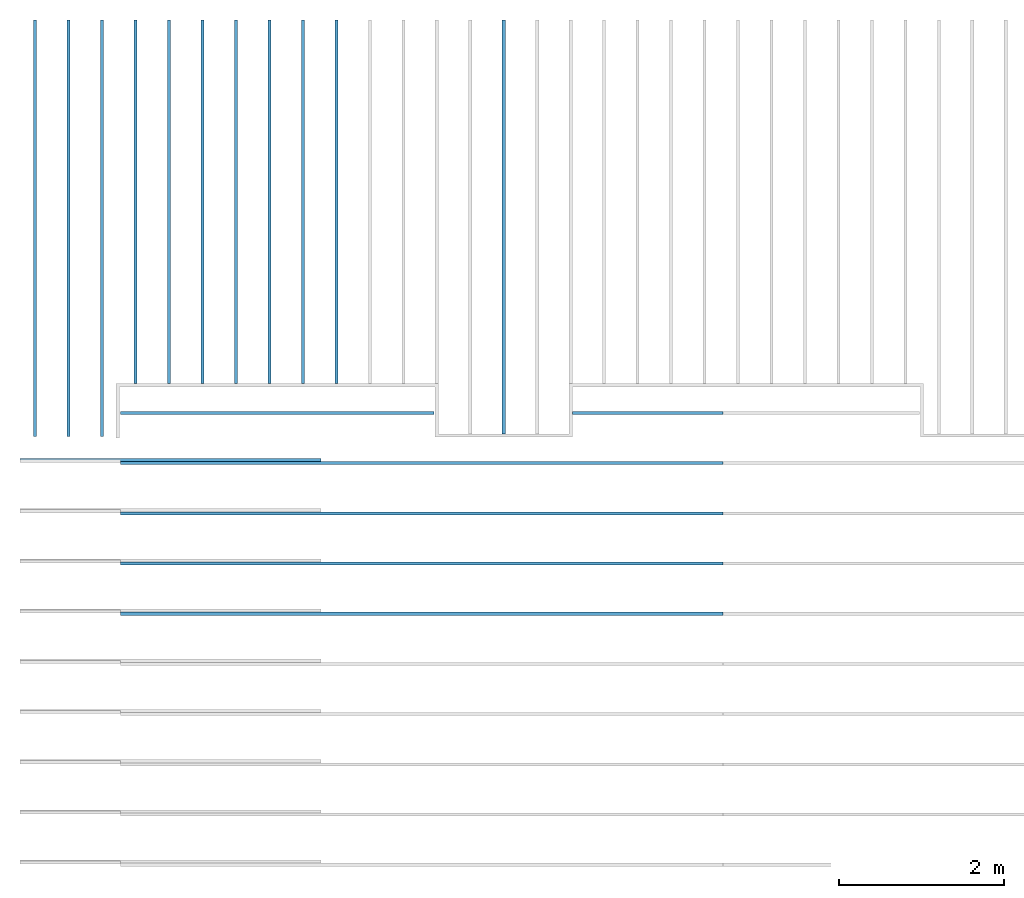
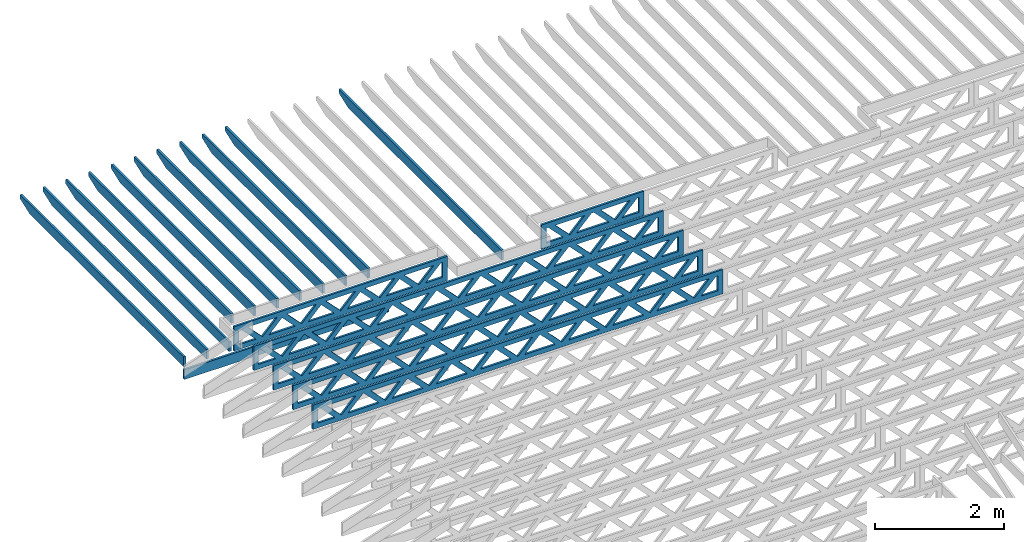
# One storey, part 4 of 17: 18 beams, 3 elements without a shape of their own.
"""IFC4 building model written with IfcOpenShell, lengths in feet."""

from ifc_helpers import new_model, entity, si_unit, converted_unit, derived_unit, direction, frame, frame_2d, origin, origin_2d_with_axis, place, context, subcontext, project, spatial, rectangle, extrude, clip, halfspace, source, transform, mapped, material, material_profile, profile_set, profile_usage, type_object, type_shapes, element, aggregate, save


model = new_model("IFC4")

# Units and contexts
model_context = context("Model", 3, precision=0.0001, world=origin(), true_north=direction((6.12303176911189e-17, 1.0)))
body_context = subcontext(model_context, "Body", "Model", "MODEL_VIEW")
ifc_project = project(units=[converted_unit("LENGTHUNIT", "FOOT", entity("IfcRatioMeasure", 0.3048), si_unit("LENGTHUNIT", "METRE"), dimensions=[1, 0, 0, 0, 0, 0, 0]), converted_unit("AREAUNIT", "SQUARE FOOT", entity("IfcRatioMeasure", 0.09290304), si_unit("AREAUNIT", "SQUARE_METRE"), dimensions=[2, 0, 0, 0, 0, 0, 0]), converted_unit("VOLUMEUNIT", "CUBIC FOOT", entity("IfcRatioMeasure", 0.028316846592), si_unit("VOLUMEUNIT", "CUBIC_METRE"), dimensions=[3, 0, 0, 0, 0, 0, 0]), converted_unit("PLANEANGLEUNIT", "DEGREE", entity("IfcRatioMeasure", 0.0174532925199433), si_unit("PLANEANGLEUNIT", "RADIAN"), dimensions=[0, 0, 0, 0, 0, 0, 0]), si_unit("MASSUNIT", "GRAM", prefix="KILO"), derived_unit("MASSDENSITYUNIT", [(si_unit("MASSUNIT", "GRAM", prefix="KILO"), 1), (si_unit("LENGTHUNIT", "METRE"), -3)]), derived_unit("MOMENTOFINERTIAUNIT", [(si_unit("LENGTHUNIT", "METRE"), 4)]), si_unit("TIMEUNIT", "SECOND"), si_unit("FREQUENCYUNIT", "HERTZ"), si_unit("THERMODYNAMICTEMPERATUREUNIT", "DEGREE_CELSIUS"), derived_unit("THERMALTRANSMITTANCEUNIT", [(si_unit("MASSUNIT", "GRAM", prefix="KILO"), 1), (si_unit("THERMODYNAMICTEMPERATUREUNIT", "KELVIN"), -1), (si_unit("TIMEUNIT", "SECOND"), -3)]), derived_unit("VOLUMETRICFLOWRATEUNIT", [(si_unit("LENGTHUNIT", "METRE"), 3), (si_unit("TIMEUNIT", "SECOND"), -1)]), si_unit("ELECTRICCURRENTUNIT", "AMPERE"), si_unit("ELECTRICVOLTAGEUNIT", "VOLT"), si_unit("POWERUNIT", "WATT"), si_unit("FORCEUNIT", "NEWTON"), si_unit("ILLUMINANCEUNIT", "LUX"), si_unit("LUMINOUSFLUXUNIT", "LUMEN"), si_unit("LUMINOUSINTENSITYUNIT", "CANDELA"), derived_unit("USERDEFINED", [(si_unit("MASSUNIT", "GRAM", prefix="KILO"), -1), (si_unit("LENGTHUNIT", "METRE"), -2), (si_unit("TIMEUNIT", "SECOND"), 3), (si_unit("LUMINOUSFLUXUNIT", "LUMEN"), 1)]), derived_unit("LINEARVELOCITYUNIT", [(si_unit("LENGTHUNIT", "METRE"), 1), (si_unit("TIMEUNIT", "SECOND"), -1)]), si_unit("PRESSUREUNIT", "PASCAL"), derived_unit("USERDEFINED", [(si_unit("LENGTHUNIT", "METRE"), -2), (si_unit("MASSUNIT", "GRAM", prefix="KILO"), 1), (si_unit("TIMEUNIT", "SECOND"), -2)]), derived_unit("LINEARFORCEUNIT", [(si_unit("MASSUNIT", "GRAM", prefix="KILO"), 1), (si_unit("LENGTHUNIT", "METRE"), 1), (si_unit("TIMEUNIT", "SECOND"), -2), (si_unit("LENGTHUNIT", "METRE"), -1)]), derived_unit("PLANARFORCEUNIT", [(si_unit("MASSUNIT", "GRAM", prefix="KILO"), 1), (si_unit("LENGTHUNIT", "METRE"), 1), (si_unit("TIMEUNIT", "SECOND"), -2), (si_unit("LENGTHUNIT", "METRE"), -2)])], contexts=[model_context])

# Site, building, storey
site_placement = place(None, origin())
site = spatial("IfcSite", under=ifc_project, at=site_placement, CompositionType="ELEMENT")
building_placement = place(site_placement, origin())
building = spatial("IfcBuilding", under=site, at=building_placement, CompositionType="ELEMENT")
storey_placement = place(building_placement, frame((0.0, 0.0, 30.4375000000082)))
storey = spatial("IfcBuildingStorey", under=building, at=storey_placement, Name="ROOF", CompositionType="ELEMENT", Elevation=30.4375000000082)

# Assembly, beams
assembly_1_placement = place(storey_placement, origin())
assembly_1 = element("IfcElementAssembly", 1, at=assembly_1_placement, inside=storey, Name="Structural Beam System:Structural Framing System", ObjectType="Structural Beam System:Structural Framing System", AssemblyPlace="NOTDEFINED", PredefinedType="BEAM_GRID")
ifc_material_1 = material(Name="WOOD TRUSS", Category="Materials")
ifc_material_profile_1 = material_profile(ifc_material_1, rectangle(XDim=1.73473973950632, YDim=0.125, at=origin_2d_with_axis()))
ifc_material_profile_2 = material_profile(ifc_material_1, rectangle(XDim=1.73473973950633, YDim=0.125, at=frame_2d((-1.11022302462516e-16, 0.0), x_axis=(1.0, 0.0))))
ifc_material_profile_3 = material_profile(ifc_material_1, rectangle(XDim=1.73473973950632, YDim=0.125, at=origin_2d_with_axis()))
ifc_material_profile_4 = material_profile(ifc_material_1, rectangle(XDim=1.73473973950633, YDim=0.125, at=origin_2d_with_axis()))
ifc_material_profile_5 = material_profile(ifc_material_1, rectangle(XDim=1.73473973950632, YDim=0.125, at=frame_2d((-5.55111512312578e-17, 0.0), x_axis=(1.0, 0.0))))
ifc_material_profile_6 = material_profile(ifc_material_1, rectangle(XDim=1.73473973950633, YDim=0.125, at=frame_2d((-2.77555756156289e-16, 0.0), x_axis=(1.0, 0.0))))
ifc_material_profile_7 = material_profile(ifc_material_1, rectangle(XDim=1.73473973950632, YDim=0.125, at=frame_2d((-4.9960036108132e-16, 0.0), x_axis=(1.0, 0.0))))
ifc_material_profile_8 = material_profile(ifc_material_1, rectangle(XDim=1.73473973950633, YDim=0.125, at=frame_2d((4.44089209850063e-16, 0.0), x_axis=(1.0, 0.0))))
ifc_material_profile_9 = material_profile(ifc_material_1, rectangle(XDim=1.73473973950632, YDim=0.125, at=origin_2d_with_axis()))
ifc_material_profile_10 = material_profile(ifc_material_1, rectangle(XDim=1.73473973950633, YDim=0.125, at=frame_2d((-4.9960036108132e-16, 0.0), x_axis=(1.0, 0.0))))
ifc_material_profile_11 = material_profile(ifc_material_1, rectangle(XDim=0.291666666666664, YDim=0.125, at=frame_2d((-2.77555756156289e-17, 0.0), x_axis=(1.0, 0.0))))
ifc_material_profile_12 = material_profile(ifc_material_1, rectangle(XDim=0.291666666666628, YDim=0.124999999999995, at=frame_2d((-5.55111512312578e-17, 0.0), x_axis=(1.0, 0.0))))
ifc_material_profile_13 = material_profile(ifc_material_1, rectangle(XDim=0.916666666666666, YDim=0.125000000000003, at=frame_2d((-2.77555756156289e-17, 0.0), x_axis=(1.0, 0.0))))
ifc_material_profile_14 = material_profile(ifc_material_1, rectangle(XDim=0.916666666666651, YDim=0.125, at=frame_2d((-2.77555756156289e-17, 0.0), x_axis=(1.0, 0.0))))
ifc_profile_set_1 = profile_set([ifc_material_profile_1, ifc_material_profile_2, ifc_material_profile_3, ifc_material_profile_4, ifc_material_profile_5, ifc_material_profile_6, ifc_material_profile_7, ifc_material_profile_8, ifc_material_profile_9, ifc_material_profile_10, ifc_material_profile_11, ifc_material_profile_12, ifc_material_profile_13, ifc_material_profile_14])
ifc_profile_usage_1 = profile_usage(ifc_profile_set_1, cardinal=8)
beam_type_1 = type_object("IfcBeamType", PredefinedType="BEAM", material=ifc_profile_set_1)
shared_shape_1 = source(origin(), body_context, "Body", "SweptSolid", [
    extrude(rectangle(XDim=1.73473973950632, YDim=0.125, at=origin_2d_with_axis()), frame((2.81172855039779, 0.0, 0.101118361020562), z_axis=(0.720569184836762, 0.0, -0.693383046997606), x_axis=(0.693383046997606, 0.0, 0.720569184836762)), (0.0, 0.0, 1.0), 0.291666666666667),
    extrude(rectangle(XDim=1.73473973950633, YDim=0.125, at=frame_2d((-1.11022302462516e-16, 0.0), x_axis=(1.0, 0.0))), frame((1.56144267672452, 0.0, -0.101118361020407), z_axis=(0.720569184836758, 0.0, 0.69338304699761), x_axis=(0.69338304699761, 0.0, -0.720569184836758)), (0.0, 0.0, 1.0), 0.291666666666666),
    extrude(rectangle(XDim=1.73473973950632, YDim=0.125, at=origin_2d_with_axis()), frame((0.520059930714936, 0.0, 0.101118361020562), z_axis=(0.720569184836762, 0.0, -0.693383046997606), x_axis=(0.693383046997606, 0.0, 0.720569184836762)), (0.0, 0.0, 1.0), 0.291666666666667),
    extrude(rectangle(XDim=1.73473973950633, YDim=0.125, at=origin_2d_with_axis()), frame((-0.730225942958334, 0.0, -0.101118361020407), z_axis=(0.720569184836758, 0.0, 0.69338304699761), x_axis=(0.69338304699761, 0.0, -0.720569184836758)), (0.0, 0.0, 1.0), 0.291666666666666),
    extrude(rectangle(XDim=1.73473973950632, YDim=0.125, at=frame_2d((-5.55111512312578e-17, 0.0), x_axis=(1.0, 0.0))), frame((-1.77160868896792, 0.0, 0.101118361020562), z_axis=(0.720569184836762, 0.0, -0.693383046997606), x_axis=(0.693383046997606, 0.0, 0.720569184836762)), (0.0, 0.0, 1.0), 0.291666666666667),
    extrude(rectangle(XDim=1.73473973950633, YDim=0.125, at=frame_2d((-2.77555756156289e-16, 0.0), x_axis=(1.0, 0.0))), frame((-3.02189456264119, 0.0, -0.101118361020407), z_axis=(0.720569184836758, 0.0, 0.69338304699761), x_axis=(0.69338304699761, 0.0, -0.720569184836758)), (0.0, 0.0, 1.0), 0.291666666666666),
    extrude(rectangle(XDim=1.73473973950632, YDim=0.125, at=frame_2d((-4.9960036108132e-16, 0.0), x_axis=(1.0, 0.0))), frame((5.10339717008065, 0.0, 0.101118361020511), z_axis=(0.720569184836761, 0.0, -0.693383046997607), x_axis=(0.693383046997607, 0.0, 0.720569184836761)), (0.0, 0.0, 1.0), 0.291666666666668),
    extrude(rectangle(XDim=1.73473973950633, YDim=0.125, at=frame_2d((4.44089209850063e-16, 0.0), x_axis=(1.0, 0.0))), frame((3.85311129640737, 0.0, -0.101118361020458), z_axis=(0.720569184836758, 0.0, 0.69338304699761), x_axis=(0.69338304699761, 0.0, -0.720569184836758)), (0.0, 0.0, 1.0), 0.291666666666666),
    extrude(rectangle(XDim=1.73473973950632, YDim=0.125, at=origin_2d_with_axis()), frame((-4.06327730865077, 0.0, 0.101118361020557), z_axis=(0.720569184836762, 0.0, -0.693383046997606), x_axis=(0.693383046997606, 0.0, 0.720569184836762)), (0.0, 0.0, 1.0), 0.291666666666668),
    extrude(rectangle(XDim=1.73473973950633, YDim=0.125, at=frame_2d((-4.9960036108132e-16, 0.0), x_axis=(1.0, 0.0))), frame((-5.31356318232404, 0.0, -0.101118361020412), z_axis=(0.720569184836758, 0.0, 0.69338304699761), x_axis=(0.69338304699761, 0.0, -0.720569184836758)), (0.0, 0.0, 1.0), 0.291666666666667),
    extrude(rectangle(XDim=0.291666666666664, YDim=0.125, at=frame_2d((-2.77555756156289e-17, 0.0), x_axis=(1.0, 0.0))), frame((-6.25000390603229, 0.0, 0.604166666666611), z_axis=(1.0, 0.0, 0.0), x_axis=(0.0, 0.0, -1.0)), (0.0, 0.0, 1.0), 12.5000078120646),
    extrude(rectangle(XDim=0.291666666666628, YDim=0.124999999999995, at=frame_2d((-5.55111512312578e-17, 0.0), x_axis=(1.0, 0.0))), frame((-6.25000390603208, 0.0, -0.604166666666693), z_axis=(1.0, 0.0, 0.0), x_axis=(0.0, 0.0, -1.0)), (0.0, 0.0, 1.0), 12.5000078120644),
    extrude(rectangle(XDim=0.916666666666666, YDim=0.125000000000003, at=frame_2d((-2.77555756156289e-17, 0.0), x_axis=(1.0, 0.0))), frame((5.9583372393656, 0.0, 0.0), z_axis=(1.0, 0.0, 0.0), x_axis=(0.0, 0.0, -1.0)), (0.0, 0.0, 1.0), 0.291666666666687),
    extrude(rectangle(XDim=0.916666666666651, YDim=0.125, at=frame_2d((-2.77555756156289e-17, 0.0), x_axis=(1.0, 0.0))), frame((-6.25000390603229, 0.0, 0.0), z_axis=(1.0, 0.0, 0.0), x_axis=(0.0, 0.0, -1.0)), (0.0, 0.0, 1.0), 0.291666666666687),
])
type_shapes(beam_type_1, [shared_shape_1])
beam_1_placement = place(assembly_1_placement, frame((-259.488164363354, 957.861934882651, 0.749999999991619)))
beam_1 = element("IfcBeam", 2, at=beam_1_placement, type_object=beam_type_1, material=ifc_profile_usage_1, PredefinedType="BEAM", context=body_context, shape_type="MappedRepresentation", body=[
    mapped(shared_shape_1, transform((0.0, 0.0, 0.0), scale=1.0)),
])
ifc_profile_usage_2 = profile_usage(ifc_profile_set_1, cardinal=8)
beam_type_2 = type_object("IfcBeamType", PredefinedType="BEAM", material=ifc_profile_set_1)
shared_shape_2 = source(origin(), body_context, "Body", "SweptSolid", [
    extrude(rectangle(XDim=1.73473973950632, YDim=0.125, at=frame_2d((5.55111512312578e-17, 0.0), x_axis=(1.0, 0.0))), frame((1.853392761574, 0.0, 0.101118361020515), z_axis=(0.720569184836762, 0.0, -0.693383046997606), x_axis=(0.693383046997606, 0.0, 0.720569184836762)), (0.0, 0.0, 1.0), 0.291666666666667),
    extrude(rectangle(XDim=1.73473973950633, YDim=0.125, at=frame_2d((-1.11022302462516e-16, 0.0), x_axis=(1.0, 0.0))), frame((0.603106887900734, 0.0, -0.101118361020454), z_axis=(0.720569184836758, 0.0, 0.69338304699761), x_axis=(0.69338304699761, 0.0, -0.720569184836758)), (0.0, 0.0, 1.0), 0.291666666666667),
    extrude(rectangle(XDim=1.73473973950632, YDim=0.125, at=frame_2d((-5.55111512312578e-17, 0.0), x_axis=(1.0, 0.0))), frame((-0.813272900144133, 0.0, 0.101118361020554), z_axis=(0.720569184836762, 0.0, -0.693383046997606), x_axis=(0.693383046997606, 0.0, 0.720569184836762)), (0.0, 0.0, 1.0), 0.291666666666667),
    extrude(rectangle(XDim=1.73473973950633, YDim=0.125, at=frame_2d((-1.66533453693773e-16, 0.0), x_axis=(1.0, 0.0))), frame((-2.0635587738174, 0.0, -0.101118361020415), z_axis=(0.720569184836758, 0.0, 0.69338304699761), x_axis=(0.69338304699761, 0.0, -0.720569184836758)), (0.0, 0.0, 1.0), 0.291666666666666),
    extrude(rectangle(XDim=0.291666666666664, YDim=0.125, at=frame_2d((-2.77555756156289e-17, 0.0), x_axis=(1.0, 0.0))), frame((-2.99999949752565, 0.0, 0.604166666666611), z_axis=(1.0, 0.0, 0.0), x_axis=(0.0, 0.0, -1.0)), (0.0, 0.0, 1.0), 5.9999989950513),
    extrude(rectangle(XDim=0.291666666666628, YDim=0.124999999999995, at=frame_2d((-5.55111512312578e-17, 0.0), x_axis=(1.0, 0.0))), frame((-2.99999949752544, 0.0, -0.604166666666693), z_axis=(1.0, 0.0, 0.0), x_axis=(0.0, 0.0, -1.0)), (0.0, 0.0, 1.0), 5.99999899505109),
    extrude(rectangle(XDim=0.916666666666666, YDim=0.125000000000003, at=frame_2d((-2.77555756156289e-17, 0.0), x_axis=(1.0, 0.0))), frame((2.70833283085896, 0.0, 0.0), z_axis=(1.0, 0.0, 0.0), x_axis=(0.0, 0.0, -1.0)), (0.0, 0.0, 1.0), 0.291666666666687),
    extrude(rectangle(XDim=0.916666666666651, YDim=0.125, at=frame_2d((-2.77555756156289e-17, 0.0), x_axis=(1.0, 0.0))), frame((-2.99999949752565, 0.0, 0.0), z_axis=(1.0, 0.0, 0.0), x_axis=(0.0, 0.0, -1.0)), (0.0, 0.0, 1.0), 0.291666666666687),
])
type_shapes(beam_type_2, [shared_shape_2])
beam_2_placement = place(assembly_1_placement, frame((-244.738159983054, 957.861934882651, 0.749999999991616)))
beam_2 = element("IfcBeam", 3, at=beam_2_placement, type_object=beam_type_2, material=ifc_profile_usage_2, PredefinedType="BEAM", context=body_context, shape_type="MappedRepresentation", body=[
    mapped(shared_shape_2, transform((0.0, 0.0, 0.0), scale=1.0)),
])
ifc_profile_usage_3 = profile_usage(ifc_profile_set_1, cardinal=8)
beam_type_3 = type_object("IfcBeamType", PredefinedType="BEAM", material=ifc_profile_set_1)
shared_shape_3 = source(origin(), body_context, "Body", "SweptSolid", [
    extrude(rectangle(XDim=1.73473973950632, YDim=0.125, at=frame_2d((8.88178419700125e-16, 0.0), x_axis=(1.0, 0.0))), frame((8.27006284966195, 0.0, 0.101118361020562), z_axis=(0.720569184836762, 0.0, -0.693383046997606), x_axis=(0.693383046997606, 0.0, 0.720569184836762)), (0.0, 0.0, 1.0), 0.291666666666667),
    extrude(rectangle(XDim=1.73473973950633, YDim=0.125, at=frame_2d((4.9960036108132e-16, 0.0), x_axis=(1.0, 0.0))), frame((7.01977697598868, 0.0, -0.101118361020407), z_axis=(0.720569184836758, 0.0, 0.69338304699761), x_axis=(0.69338304699761, 0.0, -0.720569184836758)), (0.0, 0.0, 1.0), 0.291666666666667),
    extrude(rectangle(XDim=1.73473973950632, YDim=0.125, at=origin_2d_with_axis()), frame((5.68672854334628, 0.0, 0.101118361020562), z_axis=(0.720569184836762, 0.0, -0.693383046997606), x_axis=(0.693383046997606, 0.0, 0.720569184836762)), (0.0, 0.0, 1.0), 0.291666666666667),
    extrude(rectangle(XDim=1.73473973950633, YDim=0.125, at=frame_2d((-4.9960036108132e-16, 0.0), x_axis=(1.0, 0.0))), frame((4.43644266967301, 0.0, -0.101118361020407), z_axis=(0.720569184836758, 0.0, 0.69338304699761), x_axis=(0.69338304699761, 0.0, -0.720569184836758)), (0.0, 0.0, 1.0), 0.291666666666667),
    extrude(rectangle(XDim=1.73473973950632, YDim=0.125, at=frame_2d((3.33066907387547e-16, 0.0), x_axis=(1.0, 0.0))), frame((3.10339423703061, 0.0, 0.101118361020562), z_axis=(0.720569184836762, 0.0, -0.693383046997606), x_axis=(0.693383046997606, 0.0, 0.720569184836762)), (0.0, 0.0, 1.0), 0.291666666666667),
    extrude(rectangle(XDim=1.73473973950633, YDim=0.125, at=frame_2d((-1.11022302462516e-16, 0.0), x_axis=(1.0, 0.0))), frame((1.85310836335734, 0.0, -0.101118361020407), z_axis=(0.720569184836758, 0.0, 0.69338304699761), x_axis=(0.69338304699761, 0.0, -0.720569184836758)), (0.0, 0.0, 1.0), 0.291666666666666),
    extrude(rectangle(XDim=1.73473973950632, YDim=0.125, at=frame_2d((5.55111512312578e-17, 0.0), x_axis=(1.0, 0.0))), frame((0.520059930714937, 0.0, 0.101118361020562), z_axis=(0.720569184836762, 0.0, -0.693383046997606), x_axis=(0.693383046997606, 0.0, 0.720569184836762)), (0.0, 0.0, 1.0), 0.291666666666667),
    extrude(rectangle(XDim=1.73473973950633, YDim=0.125, at=origin_2d_with_axis()), frame((-0.730225942958334, 0.0, -0.101118361020407), z_axis=(0.720569184836758, 0.0, 0.69338304699761), x_axis=(0.69338304699761, 0.0, -0.720569184836758)), (0.0, 0.0, 1.0), 0.291666666666666),
    extrude(rectangle(XDim=1.73473973950632, YDim=0.125, at=frame_2d((-5.55111512312578e-17, 0.0), x_axis=(1.0, 0.0))), frame((-2.06327437560074, 0.0, 0.101118361020562), z_axis=(0.720569184836762, 0.0, -0.693383046997606), x_axis=(0.693383046997606, 0.0, 0.720569184836762)), (0.0, 0.0, 1.0), 0.291666666666667),
    extrude(rectangle(XDim=1.73473973950633, YDim=0.125, at=frame_2d((-2.77555756156289e-16, 0.0), x_axis=(1.0, 0.0))), frame((-3.31356024927401, 0.0, -0.101118361020407), z_axis=(0.720569184836758, 0.0, 0.69338304699761), x_axis=(0.69338304699761, 0.0, -0.720569184836758)), (0.0, 0.0, 1.0), 0.291666666666666),
    extrude(rectangle(XDim=1.73473973950632, YDim=0.125, at=origin_2d_with_axis()), frame((-4.64660868191641, 0.0, 0.101118361020562), z_axis=(0.720569184836762, 0.0, -0.693383046997606), x_axis=(0.693383046997606, 0.0, 0.720569184836762)), (0.0, 0.0, 1.0), 0.291666666666667),
    extrude(rectangle(XDim=1.73473973950633, YDim=0.125, at=frame_2d((-4.9960036108132e-16, 0.0), x_axis=(1.0, 0.0))), frame((-5.89689455558968, 0.0, -0.101118361020407), z_axis=(0.720569184836758, 0.0, 0.69338304699761), x_axis=(0.69338304699761, 0.0, -0.720569184836758)), (0.0, 0.0, 1.0), 0.291666666666667),
    extrude(rectangle(XDim=1.73473973950632, YDim=0.125, at=frame_2d((5.55111512312578e-16, 0.0), x_axis=(1.0, 0.0))), frame((-7.22994298823208, 0.0, 0.101118361020562), z_axis=(0.720569184836762, 0.0, -0.693383046997606), x_axis=(0.693383046997606, 0.0, 0.720569184836762)), (0.0, 0.0, 1.0), 0.291666666666667),
    extrude(rectangle(XDim=1.73473973950633, YDim=0.125, at=origin_2d_with_axis()), frame((-8.48022886190535, 0.0, -0.101118361020407), z_axis=(0.720569184836758, 0.0, 0.69338304699761), x_axis=(0.69338304699761, 0.0, -0.720569184836758)), (0.0, 0.0, 1.0), 0.291666666666666),
    extrude(rectangle(XDim=1.73473973950632, YDim=0.125, at=frame_2d((-8.88178419700125e-16, 0.0), x_axis=(1.0, 0.0))), frame((10.8533971559776, 0.0, 0.101118361020503), z_axis=(0.720569184836762, 0.0, -0.693383046997606), x_axis=(0.693383046997606, 0.0, 0.720569184836762)), (0.0, 0.0, 1.0), 0.291666666666664),
    extrude(rectangle(XDim=1.73473973950633, YDim=0.125, at=origin_2d_with_axis()), frame((9.60311128230435, 0.0, -0.101118361020466), z_axis=(0.720569184836758, 0.0, 0.69338304699761), x_axis=(0.69338304699761, 0.0, -0.720569184836758)), (0.0, 0.0, 1.0), 0.291666666666666),
    extrude(rectangle(XDim=1.73473973950632, YDim=0.125, at=frame_2d((8.88178419700125e-16, 0.0), x_axis=(1.0, 0.0))), frame((-9.81327729454775, 0.0, 0.101118361020564), z_axis=(0.720569184836762, 0.0, -0.693383046997606), x_axis=(0.693383046997606, 0.0, 0.720569184836762)), (0.0, 0.0, 1.0), 0.291666666666667),
    extrude(rectangle(XDim=1.73473973950633, YDim=0.125, at=origin_2d_with_axis()), frame((-11.063563168221, 0.0, -0.101118361020405), z_axis=(0.720569184836758, 0.0, 0.69338304699761), x_axis=(0.69338304699761, 0.0, -0.720569184836758)), (0.0, 0.0, 1.0), 0.291666666666666),
    extrude(rectangle(XDim=0.291666666666664, YDim=0.125, at=frame_2d((-2.77555756156289e-17, 0.0), x_axis=(1.0, 0.0))), frame((-12.0000038919293, 0.0, 0.604166666666611), z_axis=(1.0, 0.0, 0.0), x_axis=(0.0, 0.0, -1.0)), (0.0, 0.0, 1.0), 24.0000077838585),
    extrude(rectangle(XDim=0.291666666666628, YDim=0.124999999999995, at=frame_2d((-5.55111512312578e-17, 0.0), x_axis=(1.0, 0.0))), frame((-12.0000038919291, 0.0, -0.604166666666693), z_axis=(1.0, 0.0, 0.0), x_axis=(0.0, 0.0, -1.0)), (0.0, 0.0, 1.0), 24.0000077838583),
    extrude(rectangle(XDim=0.916666666666666, YDim=0.125000000000003, at=frame_2d((-2.77555756156289e-17, 0.0), x_axis=(1.0, 0.0))), frame((11.7083372252626, 0.0, 0.0), z_axis=(1.0, 0.0, 0.0), x_axis=(0.0, 0.0, -1.0)), (0.0, 0.0, 1.0), 0.291666666666687),
    extrude(rectangle(XDim=0.916666666666651, YDim=0.125, at=frame_2d((-2.77555756156289e-17, 0.0), x_axis=(1.0, 0.0))), frame((-12.0000038919293, 0.0, 0.0), z_axis=(1.0, 0.0, 0.0), x_axis=(0.0, 0.0, -1.0)), (0.0, 0.0, 1.0), 0.291666666666687),
])
type_shapes(beam_type_3, [shared_shape_3])
beam_3_placement = place(assembly_1_placement, frame((-253.738164377457, 955.861934882651, 0.749999999991619)))
beam_3 = element("IfcBeam", 4, at=beam_3_placement, type_object=beam_type_3, material=ifc_profile_usage_3, PredefinedType="BEAM", context=body_context, shape_type="MappedRepresentation", body=[
    mapped(shared_shape_3, transform((0.0, 0.0, 0.0), scale=1.0)),
])
ifc_profile_usage_4 = profile_usage(ifc_profile_set_1, cardinal=8)
beam_4_placement = place(assembly_1_placement, frame((-253.738164377457, 953.861934882651, 0.749999999991623)))
beam_4 = element("IfcBeam", 5, at=beam_4_placement, type_object=beam_type_3, material=ifc_profile_usage_4, PredefinedType="BEAM", context=body_context, shape_type="MappedRepresentation", body=[
    mapped(shared_shape_3, transform((0.0, 0.0, 0.0), scale=1.0)),
])
ifc_profile_usage_5 = profile_usage(ifc_profile_set_1, cardinal=8)
beam_5_placement = place(assembly_1_placement, frame((-253.738164377457, 951.861934882651, 0.74999999999163)))
beam_5 = element("IfcBeam", 6, at=beam_5_placement, type_object=beam_type_3, material=ifc_profile_usage_5, PredefinedType="BEAM", context=body_context, shape_type="MappedRepresentation", body=[
    mapped(shared_shape_3, transform((0.0, 0.0, 0.0), scale=1.0)),
])
ifc_profile_usage_6 = profile_usage(ifc_profile_set_1, cardinal=8)
beam_6_placement = place(assembly_1_placement, frame((-253.738164377457, 949.861934882651, 0.749999999991633)))
beam_6 = element("IfcBeam", 7, at=beam_6_placement, type_object=beam_type_3, material=ifc_profile_usage_6, PredefinedType="BEAM", context=body_context, shape_type="MappedRepresentation", body=[
    mapped(shared_shape_3, transform((0.0, 0.0, 0.0), scale=1.0)),
])
aggregate(assembly_1, [beam_1, beam_2, beam_3, beam_4, beam_5, beam_6])

# Assembly, beam
assembly_2_placement = place(storey_placement, origin())
assembly_2 = element("IfcElementAssembly", 8, at=assembly_2_placement, inside=storey, Name="Structural Beam System:Structural Framing System", ObjectType="Structural Beam System:Structural Framing System", AssemblyPlace="NOTDEFINED", PredefinedType="BEAM_GRID")
ifc_material_2 = material(Name="2X8 TO ROOF", Category="Materials")
ifc_material_profile_15 = material_profile(ifc_material_2, rectangle(XDim=0.604166666666667, YDim=0.125000000000011, at=origin_2d_with_axis()), Name="2X8")
ifc_profile_set_2 = profile_set([ifc_material_profile_15], Name="2X8")
ifc_profile_usage_7 = profile_usage(ifc_profile_set_2, cardinal=8)
beam_type_4 = type_object("IfcBeamType", Name="061100 - Wood Framing:2X8", PredefinedType="BEAM", material=ifc_profile_set_2)
shared_shape_4 = source(origin(), body_context, "Body", "SweptSolid", [
    extrude(rectangle(XDim=0.604166666666667, YDim=0.125000000000011, at=origin_2d_with_axis()), frame((-6.0, 0.0, 0.0), z_axis=(1.0, 0.0, 0.0), x_axis=(0.0, 0.0, -1.0)), (0.0, 0.0, 1.0), 12.000000000033),
])
type_shapes(beam_type_4, [shared_shape_4])
beam_7_placement = place(assembly_2_placement, frame((-263.738042691372, 955.986939928224, 1.0729166666584), z_axis=(0.0, 0.0, 1.0), x_axis=(-1.0, 0.0, 0.0)))
beam_7 = element("IfcBeam", 9, at=beam_7_placement, type_object=beam_type_4, material=ifc_profile_usage_7, Name="061100 - Wood Framing:2X8", ObjectType="061100 - Wood Framing:2X8", PredefinedType="BEAM", context=body_context, shape_type="MappedRepresentation", body=[
    mapped(shared_shape_4, transform((0.0, 0.0, 0.0), scale=1.0)),
])
aggregate(assembly_2, [beam_7])

# Assembly, beams
assembly_3_placement = place(storey_placement, origin())
assembly_3 = element("IfcElementAssembly", 10, at=assembly_3_placement, inside=storey, Name="Structural Beam System:Structural Framing System", ObjectType="Structural Beam System:Structural Framing System", AssemblyPlace="NOTDEFINED", PredefinedType="BEAM_GRID")
ifc_material_3 = material(Name="2X ROOF JOISTS - EXT. STAIN-1 - SEE LIFE SAFETY", Category="Materials")
ifc_material_profile_16 = material_profile(ifc_material_3, rectangle(XDim=0.604166666666667, YDim=0.125000000000011, at=frame_2d((0.0, 0.0), x_axis=(0.0, 1.0))))
ifc_profile_set_3 = profile_set([ifc_material_profile_16])
ifc_profile_usage_8 = profile_usage(ifc_profile_set_3, cardinal=8)
beam_type_5 = type_object("IfcBeamType", PredefinedType="BEAM", material=ifc_profile_set_3)
shared_shape_5 = source(origin(), body_context, "Body", "Clipping", [
    clip(extrude(rectangle(XDim=0.604166666666667, YDim=0.125000000000011, at=frame_2d((0.0, 0.0), x_axis=(0.0, 1.0))), frame((-8.24296473987818, 0.0, 0.0), z_axis=(1.0, 0.0, 0.0), x_axis=(0.0, 1.0, 0.0)), (0.0, 0.0, 1.0), 16.4859294797564), halfspace(frame((-7.26989982048795, -0.0625000000000026, -0.30208333333334), z_axis=(-0.34202014332567, 0.0, -0.939692620785908), x_axis=(0.0, 1.0, 0.0)), False)),
])
type_shapes(beam_type_5, [shared_shape_5])
beam_8_placement = place(assembly_3_placement, frame((-250.467327152128, 965.271566289195, 1.07291666665834), z_axis=(0.0, 0.0, 1.0), x_axis=(0.0, -1.0, 0.0)))
beam_8 = element("IfcBeam", 11, at=beam_8_placement, type_object=beam_type_5, material=ifc_profile_usage_8, PredefinedType="BEAM", context=body_context, shape_type="MappedRepresentation", body=[
    mapped(shared_shape_5, transform((0.0, 0.0, 0.0), scale=1.0)),
])
ifc_profile_usage_9 = profile_usage(ifc_profile_set_3, cardinal=8)
beam_type_6 = type_object("IfcBeamType", PredefinedType="BEAM", material=ifc_profile_set_3)
shared_shape_6 = source(origin(), body_context, "Body", "Clipping", [
    clip(extrude(rectangle(XDim=0.604166666666667, YDim=0.125000000000011, at=frame_2d((0.0, -5.55111512312578e-17), x_axis=(0.0, 1.0))), frame((-7.24296499610176, 0.0, 0.0), z_axis=(1.0, 0.0, 0.0), x_axis=(0.0, 1.0, 0.0)), (0.0, 0.0, 1.0), 14.4859299922035), halfspace(frame((-6.26990007671154, -0.0625000000000026, -0.30208333333334), z_axis=(-0.34202014332567, 0.0, -0.939692620785908), x_axis=(0.0, 1.0, 0.0)), False)),
])
type_shapes(beam_type_6, [shared_shape_6])
beam_9_placement = place(assembly_3_placement, frame((-257.133993818795, 966.271566032972, 1.07291666665843), z_axis=(0.0, 0.0, 1.0), x_axis=(0.0, -1.0, 0.0)))
beam_9 = element("IfcBeam", 12, at=beam_9_placement, type_object=beam_type_6, material=ifc_profile_usage_9, PredefinedType="BEAM", context=body_context, shape_type="MappedRepresentation", body=[
    mapped(shared_shape_6, transform((0.0, 0.0, 0.0), scale=1.0)),
])
ifc_profile_usage_10 = profile_usage(ifc_profile_set_3, cardinal=8)
beam_10_placement = place(assembly_3_placement, frame((-258.467327152129, 966.271566032972, 1.07291666665844), z_axis=(0.0, 0.0, 1.0), x_axis=(0.0, -1.0, 0.0)))
beam_10 = element("IfcBeam", 13, at=beam_10_placement, type_object=beam_type_6, material=ifc_profile_usage_10, PredefinedType="BEAM", context=body_context, shape_type="MappedRepresentation", body=[
    mapped(shared_shape_6, transform((0.0, 0.0, 0.0), scale=1.0)),
])
ifc_profile_usage_11 = profile_usage(ifc_profile_set_3, cardinal=8)
beam_11_placement = place(assembly_3_placement, frame((-259.800660485462, 966.271566032972, 1.07291666665844), z_axis=(0.0, 0.0, 1.0), x_axis=(0.0, -1.0, 0.0)))
beam_11 = element("IfcBeam", 14, at=beam_11_placement, type_object=beam_type_6, material=ifc_profile_usage_11, PredefinedType="BEAM", context=body_context, shape_type="MappedRepresentation", body=[
    mapped(shared_shape_6, transform((0.0, 0.0, 0.0), scale=1.0)),
])
ifc_profile_usage_12 = profile_usage(ifc_profile_set_3, cardinal=8)
beam_12_placement = place(assembly_3_placement, frame((-261.133993818795, 966.271566032972, 1.07291666665844), z_axis=(0.0, 0.0, 1.0), x_axis=(0.0, -1.0, 0.0)))
beam_12 = element("IfcBeam", 15, at=beam_12_placement, type_object=beam_type_6, material=ifc_profile_usage_12, PredefinedType="BEAM", context=body_context, shape_type="MappedRepresentation", body=[
    mapped(shared_shape_6, transform((0.0, 0.0, 0.0), scale=1.0)),
])
ifc_profile_usage_13 = profile_usage(ifc_profile_set_3, cardinal=8)
beam_13_placement = place(assembly_3_placement, frame((-262.467327152129, 966.271566032972, 1.07291666665845), z_axis=(0.0, 0.0, 1.0), x_axis=(0.0, -1.0, 0.0)))
beam_13 = element("IfcBeam", 16, at=beam_13_placement, type_object=beam_type_6, material=ifc_profile_usage_13, PredefinedType="BEAM", context=body_context, shape_type="MappedRepresentation", body=[
    mapped(shared_shape_6, transform((0.0, 0.0, 0.0), scale=1.0)),
])
ifc_profile_usage_14 = profile_usage(ifc_profile_set_3, cardinal=8)
beam_14_placement = place(assembly_3_placement, frame((-263.800660485462, 966.271566032972, 1.07291666665845), z_axis=(0.0, 0.0, 1.0), x_axis=(0.0, -1.0, 0.0)))
beam_14 = element("IfcBeam", 17, at=beam_14_placement, type_object=beam_type_6, material=ifc_profile_usage_14, PredefinedType="BEAM", context=body_context, shape_type="MappedRepresentation", body=[
    mapped(shared_shape_6, transform((0.0, 0.0, 0.0), scale=1.0)),
])
ifc_profile_usage_15 = profile_usage(ifc_profile_set_3, cardinal=8)
beam_15_placement = place(assembly_3_placement, frame((-265.133993818795, 966.271566032972, 1.07291666665846), z_axis=(0.0, 0.0, 1.0), x_axis=(0.0, -1.0, 0.0)))
beam_15 = element("IfcBeam", 18, at=beam_15_placement, type_object=beam_type_6, material=ifc_profile_usage_15, PredefinedType="BEAM", context=body_context, shape_type="MappedRepresentation", body=[
    mapped(shared_shape_6, transform((0.0, 0.0, 0.0), scale=1.0)),
])
ifc_profile_usage_16 = profile_usage(ifc_profile_set_3, cardinal=8)
beam_type_7 = type_object("IfcBeamType", PredefinedType="BEAM", material=ifc_profile_set_3)
shared_shape_7 = source(origin(), body_context, "Body", "Clipping", [
    clip(extrude(rectangle(XDim=0.604166666666667, YDim=0.125000000000011, at=frame_2d((0.0, 0.0), x_axis=(0.0, 1.0))), frame((-8.29610169621611, 0.0, 0.0), z_axis=(1.0, 0.0, 0.0), x_axis=(0.0, 1.0, 0.0)), (0.0, 0.0, 1.0), 16.5922033924322), halfspace(frame((-7.32303677682588, -0.0625000000000026, -0.30208333333334), z_axis=(-0.34202014332567, 0.0, -0.939692620785908), x_axis=(0.0, 1.0, 0.0)), False)),
])
type_shapes(beam_type_7, [shared_shape_7])
beam_16_placement = place(assembly_3_placement, frame((-266.467327152129, 965.218429332857, 1.07291666665835), z_axis=(0.0, 0.0, 1.0), x_axis=(0.0, -1.0, 0.0)))
beam_16 = element("IfcBeam", 19, at=beam_16_placement, type_object=beam_type_7, material=ifc_profile_usage_16, PredefinedType="BEAM", context=body_context, shape_type="MappedRepresentation", body=[
    mapped(shared_shape_7, transform((0.0, 0.0, 0.0), scale=1.0)),
])
ifc_profile_usage_17 = profile_usage(ifc_profile_set_3, cardinal=8)
beam_17_placement = place(assembly_3_placement, frame((-267.800660485462, 965.218429332857, 1.07291666665835), z_axis=(0.0, 0.0, 1.0), x_axis=(0.0, -1.0, 0.0)))
beam_17 = element("IfcBeam", 20, at=beam_17_placement, type_object=beam_type_7, material=ifc_profile_usage_17, PredefinedType="BEAM", context=body_context, shape_type="MappedRepresentation", body=[
    mapped(shared_shape_7, transform((0.0, 0.0, 0.0), scale=1.0)),
])
ifc_profile_usage_18 = profile_usage(ifc_profile_set_3, cardinal=8)
beam_18_placement = place(assembly_3_placement, frame((-269.133993818795, 965.218429332857, 1.07291666665835), z_axis=(0.0, 0.0, 1.0), x_axis=(0.0, -1.0, 0.0)))
beam_18 = element("IfcBeam", 21, at=beam_18_placement, type_object=beam_type_7, material=ifc_profile_usage_18, PredefinedType="BEAM", context=body_context, shape_type="MappedRepresentation", body=[
    mapped(shared_shape_7, transform((0.0, 0.0, 0.0), scale=1.0)),
])
aggregate(assembly_3, [beam_8, beam_9, beam_10, beam_11, beam_12, beam_13, beam_14, beam_15, beam_16, beam_17, beam_18])

save(model, "model.ifc")
